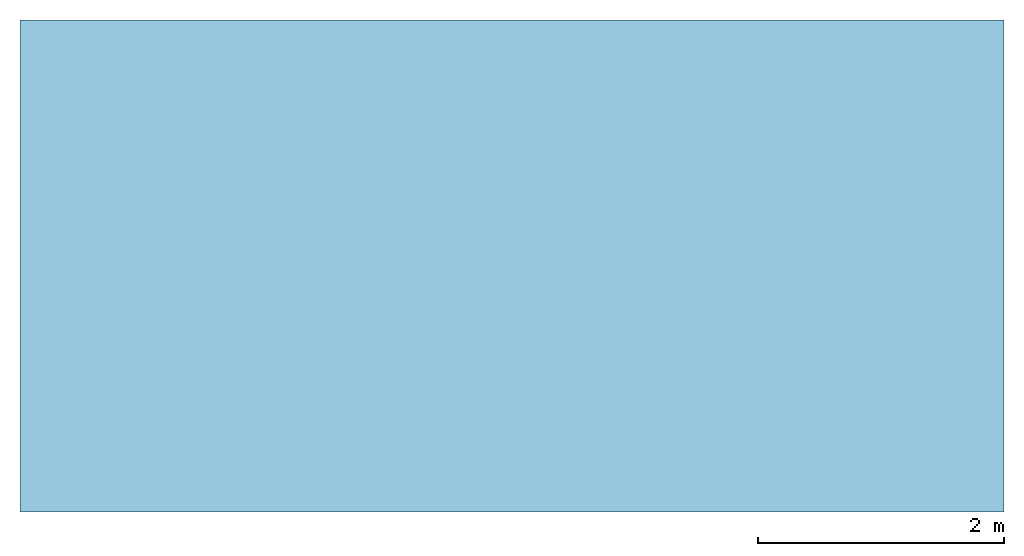
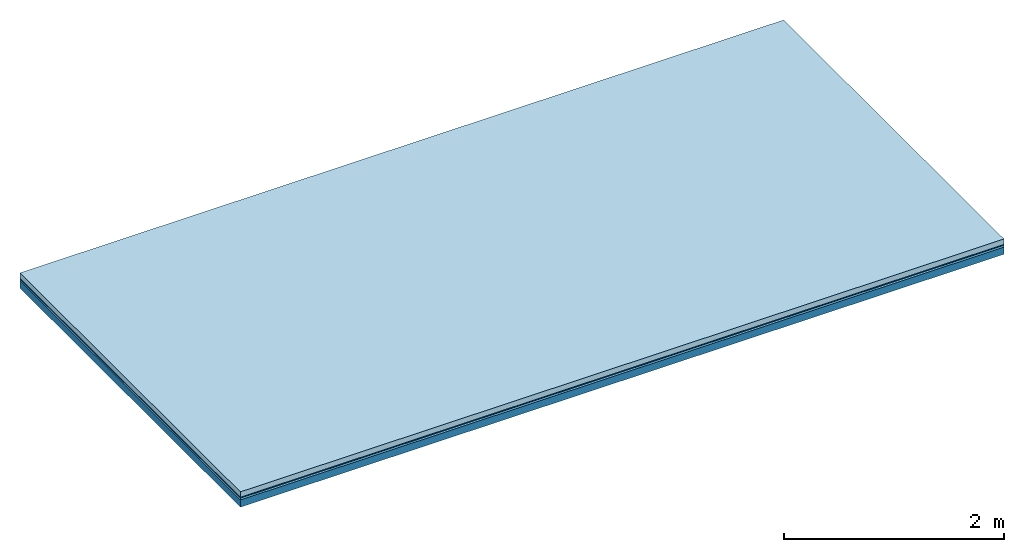
# One storey: 3 plates, 1 member, 1 element without a shape of its own.
"""IFC4 building model written with IfcOpenShell, lengths in metres."""

from ifc_helpers import new_model, si_unit, derived_unit, direction, frame, frame_2d, origin, origin_with_axes, place, context, project, spatial, rectangle, extrude, material, layer, layer_set, type_object, element, aggregate, save


model = new_model("IFC4")

# Units and contexts
plan_context = context("Plan", 3, precision=1e-05, world=origin(), true_north=direction((0.0, 1.0)))
model_context = context("Model", 3, precision=1e-05, world=origin(), true_north=direction((0.0, 1.0)))
ifc_project = project(units=[si_unit("LENGTHUNIT", "METRE"), derived_unit("SOUNDPRESSUREUNIT", [(si_unit("PRESSUREUNIT", "PASCAL", prefix="MICRO"), 0)]), si_unit("ENERGYUNIT", "JOULE", prefix="MEGA"), si_unit("MASSUNIT", "GRAM", prefix="KILO"), derived_unit("THERMALTRANSMITTANCEUNIT", [(si_unit("POWERUNIT", "WATT"), 1), (si_unit("AREAUNIT", "SQUARE_METRE"), -1), (si_unit("THERMODYNAMICTEMPERATUREUNIT", "KELVIN"), -1)]), derived_unit("AREADENSITYUNIT", [(si_unit("MASSUNIT", "GRAM", prefix="KILO"), 1), (si_unit("AREAUNIT", "SQUARE_METRE"), -1)]), derived_unit("USERDEFINED", [(si_unit("ENERGYUNIT", "JOULE", prefix="MEGA"), 1), (si_unit("AREAUNIT", "SQUARE_METRE"), -1)])], contexts=[plan_context, model_context])

# Site, building, storey
site = spatial("IfcSite", under=ifc_project)
building_placement = place(None, origin())
building = spatial("IfcBuilding", under=site, at=building_placement)
storey_placement = place(building_placement, origin())
storey = spatial("IfcBuildingStorey", under=building, at=storey_placement)

# Slab, member, plates
ifc_material_1 = material(Name="clay", Category="02.004")
ifc_layer_1 = layer(ifc_material_1, 0.06, Name="Use and protection layer 2")
ifc_material_2 = material(Name="Protective layer", Category="09.007")
ifc_layer_2 = layer(ifc_material_2, 0.01, Name="Use and protection layer 1")
ifc_material_3 = material(Name="Bituminous", Category="09.003")
ifc_layer_3 = layer(ifc_material_3, 0.02, Name="Seal")
ifc_material_4 = material(Name="no composite action")
ifc_layer_4 = layer(ifc_material_4, 0.0, Name="Bond")
ifc_layer_5 = layer(None, 0.08, Name="Support")
ifc_layer_set = layer_set([ifc_layer_1, ifc_layer_2, ifc_layer_3, ifc_layer_4, ifc_layer_5])
slab_type = type_object("IfcSlabType", Name="F0029", PredefinedType="NOTDEFINED", material=ifc_layer_set)
slab_placement = place(None, frame((0.0, 0.0, 0.0), z_axis=(0.0, 0.0, -1.0), x_axis=(1.0, 0.0, 0.0)))
slab = element("IfcSlab", 1, at=slab_placement, inside=storey, type_object=slab_type, material=ifc_layer_set, Name="Slab #1")
ifc_material_5 = material(Name="Solid timber panel")
member_placement = place(slab_placement, origin())
member = element("IfcMember", 2, at=member_placement, material=ifc_material_5, Name="Support", context=plan_context, shape_type="SweptSolid", body=[
    extrude(rectangle(XDim=1.0, YDim=0.08, at=frame_2d((0.5, 0.04), x_axis=(1.0, 0.0))), frame((0.0, 4.0, 0.09), z_axis=(0.0, -1.0, 0.0), x_axis=(1.0, 0.0, 0.0)), (0.0, 0.0, 1.0), 4.0),
    extrude(rectangle(XDim=1.0, YDim=0.08, at=frame_2d((0.5, 0.04), x_axis=(1.0, 0.0))), frame((1.0, 4.0, 0.09), z_axis=(0.0, -1.0, 0.0), x_axis=(1.0, 0.0, 0.0)), (0.0, 0.0, 1.0), 4.0),
    extrude(rectangle(XDim=1.0, YDim=0.08, at=frame_2d((0.5, 0.04), x_axis=(1.0, 0.0))), frame((2.0, 4.0, 0.09), z_axis=(0.0, -1.0, 0.0), x_axis=(1.0, 0.0, 0.0)), (0.0, 0.0, 1.0), 4.0),
    extrude(rectangle(XDim=1.0, YDim=0.08, at=frame_2d((0.5, 0.04), x_axis=(1.0, 0.0))), frame((3.0, 4.0, 0.09), z_axis=(0.0, -1.0, 0.0), x_axis=(1.0, 0.0, 0.0)), (0.0, 0.0, 1.0), 4.0),
    extrude(rectangle(XDim=1.0, YDim=0.08, at=frame_2d((0.5, 0.04), x_axis=(1.0, 0.0))), frame((4.0, 4.0, 0.09), z_axis=(0.0, -1.0, 0.0), x_axis=(1.0, 0.0, 0.0)), (0.0, 0.0, 1.0), 4.0),
    extrude(rectangle(XDim=1.0, YDim=0.08, at=frame_2d((0.5, 0.04), x_axis=(1.0, 0.0))), frame((5.0, 4.0, 0.09), z_axis=(0.0, -1.0, 0.0), x_axis=(1.0, 0.0, 0.0)), (0.0, 0.0, 1.0), 4.0),
    extrude(rectangle(XDim=1.0, YDim=0.08, at=frame_2d((0.5, 0.04), x_axis=(1.0, 0.0))), frame((6.0, 4.0, 0.09), z_axis=(0.0, -1.0, 0.0), x_axis=(1.0, 0.0, 0.0)), (0.0, 0.0, 1.0), 4.0),
    extrude(rectangle(XDim=1.0, YDim=0.08, at=frame_2d((0.5, 0.04), x_axis=(1.0, 0.0))), frame((7.0, 4.0, 0.09), z_axis=(0.0, -1.0, 0.0), x_axis=(1.0, 0.0, 0.0)), (0.0, 0.0, 1.0), 4.0),
])
plate_1_placement = place(slab_placement, origin())
plate_1 = element("IfcPlate", 3, at=plate_1_placement, material=ifc_material_1, Name="Use and protection layer 2", context=plan_context, shape_type="SweptSolid", body=[
    extrude(rectangle(XDim=8.0, YDim=4.0, at=frame_2d((4.0, 2.0), x_axis=(1.0, 0.0))), origin_with_axes(), (0.0, 0.0, 1.0), 0.06),
])
plate_2_placement = place(slab_placement, origin())
plate_2 = element("IfcPlate", 4, at=plate_2_placement, material=ifc_material_2, Name="Use and protection layer 1", context=plan_context, shape_type="SweptSolid", body=[
    extrude(rectangle(XDim=8.0, YDim=4.0, at=frame_2d((4.0, 2.0), x_axis=(1.0, 0.0))), frame((0.0, 0.0, 0.06), z_axis=(0.0, 0.0, 1.0), x_axis=(1.0, 0.0, 0.0)), (0.0, 0.0, 1.0), 0.01),
])
plate_3_placement = place(slab_placement, origin())
plate_3 = element("IfcPlate", 5, at=plate_3_placement, material=ifc_material_3, Name="Seal", context=plan_context, shape_type="SweptSolid", body=[
    extrude(rectangle(XDim=8.0, YDim=4.0, at=frame_2d((4.0, 2.0), x_axis=(1.0, 0.0))), frame((0.0, 0.0, 0.07), z_axis=(0.0, 0.0, 1.0), x_axis=(1.0, 0.0, 0.0)), (0.0, 0.0, 1.0), 0.02),
])
aggregate(slab, [plate_1, plate_2, plate_3, member])

save(model, "model.ifc")
